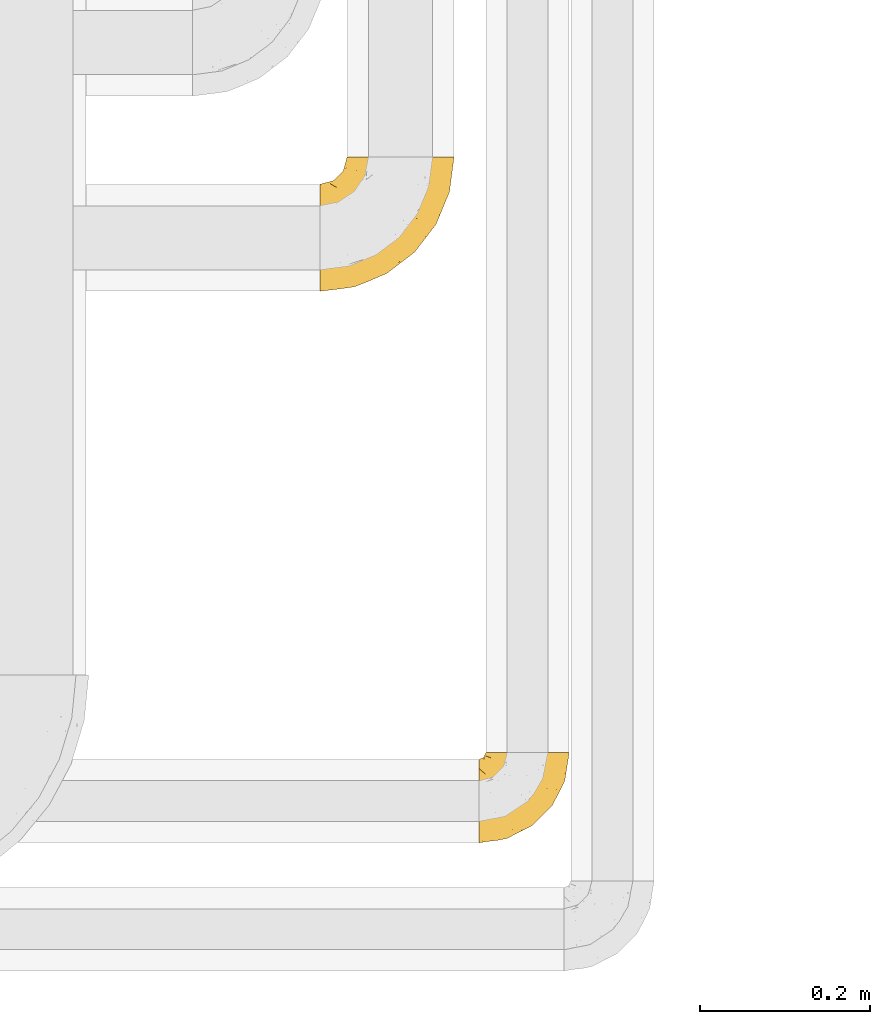
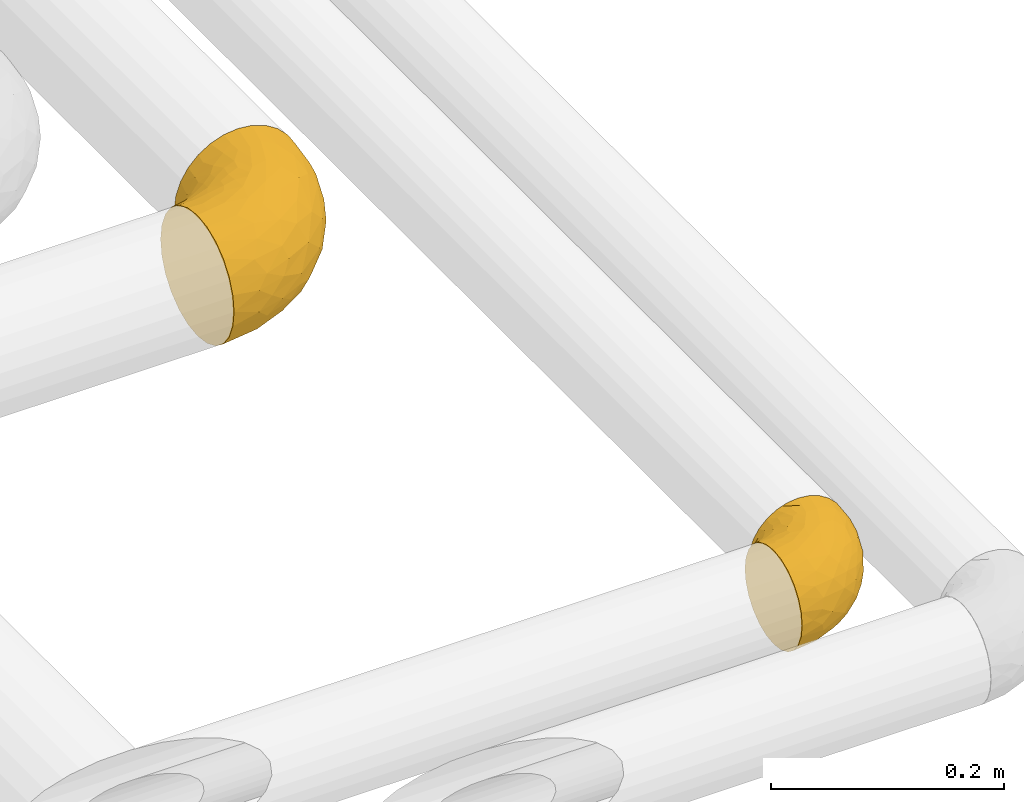
# One storey, part 486 of 827: 2 coverings.
"""IFC2X3 building model written with IfcOpenShell, lengths in millimetres."""

from ifc_helpers import new_model, entity, si_unit, converted_unit, derived_unit, direction, frame, origin, place, context, subcontext, project, spatial, faceted_brep, element, save


model = new_model("IFC2X3")

# Units and contexts
model_context = context("Model", 3, precision=0.01, world=origin(), true_north=direction((6.12303176911189e-17, 1.0)))
body_context = subcontext(model_context, "Body", "Model", "MODEL_VIEW")
ifc_project = project(units=[si_unit("LENGTHUNIT", "METRE", prefix="MILLI"), si_unit("AREAUNIT", "SQUARE_METRE"), si_unit("VOLUMEUNIT", "CUBIC_METRE"), converted_unit("PLANEANGLEUNIT", "DEGREE", entity("IfcRatioMeasure", 0.0174532925199433), si_unit("PLANEANGLEUNIT", "RADIAN"), dimensions=[0, 0, 0, 0, 0, 0, 0]), si_unit("MASSUNIT", "GRAM", prefix="KILO"), derived_unit("MASSDENSITYUNIT", [(si_unit("MASSUNIT", "GRAM", prefix="KILO"), 1), (si_unit("LENGTHUNIT", "METRE"), -3)]), derived_unit("MOMENTOFINERTIAUNIT", [(si_unit("LENGTHUNIT", "METRE"), 4)]), si_unit("TIMEUNIT", "SECOND"), si_unit("FREQUENCYUNIT", "HERTZ"), si_unit("THERMODYNAMICTEMPERATUREUNIT", "DEGREE_CELSIUS"), derived_unit("THERMALTRANSMITTANCEUNIT", [(si_unit("MASSUNIT", "GRAM", prefix="KILO"), 1), (si_unit("THERMODYNAMICTEMPERATUREUNIT", "KELVIN"), -1), (si_unit("TIMEUNIT", "SECOND"), -3)]), derived_unit("VOLUMETRICFLOWRATEUNIT", [(si_unit("LENGTHUNIT", "METRE"), 3), (si_unit("TIMEUNIT", "SECOND"), -1)]), derived_unit("MASSFLOWRATEUNIT", [(si_unit("MASSUNIT", "GRAM", prefix="KILO"), 1), (si_unit("TIMEUNIT", "SECOND"), -1)]), derived_unit("ROTATIONALFREQUENCYUNIT", [(si_unit("TIMEUNIT", "SECOND"), -1)]), si_unit("ELECTRICCURRENTUNIT", "AMPERE"), si_unit("ELECTRICVOLTAGEUNIT", "VOLT"), si_unit("POWERUNIT", "WATT"), si_unit("FORCEUNIT", "NEWTON", prefix="KILO"), si_unit("ILLUMINANCEUNIT", "LUX"), si_unit("LUMINOUSFLUXUNIT", "LUMEN"), si_unit("LUMINOUSINTENSITYUNIT", "CANDELA"), derived_unit("USERDEFINED", [(si_unit("MASSUNIT", "GRAM", prefix="KILO"), -1), (si_unit("LENGTHUNIT", "METRE"), -2), (si_unit("TIMEUNIT", "SECOND"), 3), (si_unit("LUMINOUSFLUXUNIT", "LUMEN"), 1)]), derived_unit("LINEARVELOCITYUNIT", [(si_unit("LENGTHUNIT", "METRE"), 1), (si_unit("TIMEUNIT", "SECOND"), -1)]), si_unit("PRESSUREUNIT", "PASCAL"), derived_unit("USERDEFINED", [(si_unit("LENGTHUNIT", "METRE"), -2), (si_unit("MASSUNIT", "GRAM", prefix="KILO"), 1), (si_unit("TIMEUNIT", "SECOND"), -2)]), derived_unit("LINEARFORCEUNIT", [(si_unit("MASSUNIT", "GRAM", prefix="KILO"), 1), (si_unit("LENGTHUNIT", "METRE"), 1), (si_unit("TIMEUNIT", "SECOND"), -2), (si_unit("LENGTHUNIT", "METRE"), -1)]), derived_unit("PLANARFORCEUNIT", [(si_unit("MASSUNIT", "GRAM", prefix="KILO"), 1), (si_unit("LENGTHUNIT", "METRE"), 1), (si_unit("TIMEUNIT", "SECOND"), -2), (si_unit("LENGTHUNIT", "METRE"), -2)])], contexts=[model_context])

# Site, building, storey
site_placement = place(None, origin())
site = spatial("IfcSite", under=ifc_project, at=site_placement, CompositionType="ELEMENT")
building_placement = place(site_placement, origin())
building = spatial("IfcBuilding", under=site, at=building_placement, CompositionType="ELEMENT")
storey_placement = place(building_placement, frame((0.0, 0.0, 28200.0)))
storey = spatial("IfcBuildingStorey", under=building, at=storey_placement, Name="08", CompositionType="ELEMENT", Elevation=28200.0)

# Coverings
covering_1_placement = place(storey_placement, frame((60806.51, 7015.35, 3035.35)))
element("IfcCovering", 1, at=covering_1_placement, inside=storey, Name=":ADSK_", ObjectType=":ADSK_", PredefinedType="INSULATION", context=body_context, shape_type="Brep", body=[
    faceted_brep([(110.62, 159.65, 126.11), (123.95, 159.65, 121.45), (135.9, 159.65, 113.94), (145.89, 159.65, 103.96), (153.4, 159.65, 92.0), (158.06, 159.65, 78.68), (159.65, 159.65, 64.65), (158.06, 159.65, 50.62), (153.4, 159.65, 37.29), (145.89, 159.65, 25.34), (135.91, 159.65, 15.35), (123.95, 159.65, 7.84), (110.63, 159.65, 3.18), (96.6, 159.65, 1.6), (82.57, 159.65, 3.18), (69.24, 159.65, 7.84), (57.29, 159.65, 15.35), (47.3, 159.65, 25.33), (39.79, 159.65, 37.29), (35.13, 159.65, 50.61), (33.55, 159.65, 64.65), (35.13, 159.65, 78.67), (39.79, 159.65, 92.0), (47.3, 159.65, 103.95), (57.28, 159.65, 113.94), (69.24, 159.65, 121.45), (82.56, 159.65, 126.11), (96.6, 159.65, 127.7), (1.6, 127.7, 64.65), (1.6, 125.55, 48.33), (1.6, 119.25, 33.12), (1.6, 109.23, 20.06), (1.6, 96.17, 10.04), (1.6, 80.96, 3.74), (1.6, 75.35, 3.01), (1.6, 64.65, 1.6), (1.6, 48.33, 3.74), (1.6, 33.12, 10.04), (1.6, 20.06, 20.06), (1.6, 10.04, 33.12), (1.6, 3.74, 48.33), (1.6, 1.6, 64.65), (1.6, 3.74, 80.96), (1.6, 10.04, 96.17), (1.6, 20.06, 109.23), (1.6, 33.12, 119.25), (1.6, 48.33, 125.55), (1.6, 64.65, 127.7), (1.6, 75.35, 126.29), (1.6, 80.96, 125.55), (1.6, 96.17, 119.25), (1.6, 109.23, 109.23), (1.6, 119.25, 96.17), (1.6, 125.55, 80.96), (30.13, 16.01, 101.1), (39.4, 10.29, 86.72), (62.65, 24.76, 98.7), (28.52, 4.94, 75.93), (42.5, 6.98, 64.65), (115.57, 87.32, 113.39), (98.94, 62.3, 111.06), (111.29, 58.52, 96.87), (95.5, 36.35, 84.07), (80.62, 22.77, 64.65), (113.35, 47.89, 64.65), (43.71, 40.91, 119.56), (70.76, 42.82, 112.75), (62.71, 57.25, 122.85), (33.16, 51.19, 125.08), (53.41, 66.64, 126.64), (130.65, 98.56, 105.78), (137.68, 94.44, 93.81), (146.84, 123.53, 96.07), (66.58, 20.12, 87.11), (57.7, 12.95, 75.77), (39.88, 28.48, 111.99), (154.26, 118.74, 64.65), (152.07, 121.88, 83.58), (125.54, 65.08, 80.96), (142.81, 92.08, 78.34), (103.99, 98.53, 122.85), (79.4, 81.84, 125.88), (88.81, 72.43, 120.97), (104.86, 134.31, 126.67), (117.38, 129.11, 122.64), (57.43, 82.79, 127.7), (44.19, 76.04, 127.7), (30.95, 69.29, 127.7), (139.96, 129.58, 107.12), (127.03, 115.86, 115.07), (87.17, 42.36, 102.81), (78.45, 103.81, 127.7), (73.2, 98.55, 127.7), (67.94, 93.3, 127.7), (94.63, 147.25, 127.7), (93.29, 138.77, 127.7), (91.95, 130.29, 127.7), (94.6, 107.83, 126.64), (85.2, 117.05, 127.7), (138.47, 80.62, 64.65), (13.99, 66.61, 127.7), (40.46, 121.29, 113.05), (32.36, 128.09, 101.81), (28.71, 118.04, 108.46), (15.53, 79.47, 126.21), (29.06, 94.94, 122.65), (40.03, 86.01, 126.55), (45.36, 94.69, 125.45), (26.46, 83.06, 126.01), (47.56, 104.39, 123.3), (36.28, 107.01, 118.99), (55.57, 148.3, 113.51), (45.02, 143.82, 104.6), (57.55, 134.19, 118.04), (11.56, 116.87, 101.6), (19.2, 111.58, 109.98), (10.07, 122.36, 92.1), (21.04, 124.16, 96.28), (15.52, 94.28, 121.05), (13.84, 128.25, 79.4), (32.67, 146.72, 79.19), (24.86, 134.92, 80.39), (34.31, 138.87, 93.14), (81.47, 133.28, 126.75), (71.26, 121.77, 125.71), (81.64, 145.83, 126.17), (29.26, 143.67, 64.65), (70.65, 139.93, 123.28), (31.93, 153.63, 64.65), (27.99, 132.32, 91.58), (41.71, 132.59, 107.1), (50.14, 126.42, 116.28), (17.57, 102.97, 116.32), (37.62, 149.52, 90.34), (60.48, 120.88, 122.74), (17.57, 131.98, 64.65), (56.96, 96.12, 126.77), (48.98, 115.84, 119.84), (57.29, 108.2, 124.71), (68.25, 110.85, 126.47), (10.07, 122.36, 37.19), (16.58, 118.35, 27.66), (13.84, 128.25, 49.9), (13.99, 66.61, 1.6), (32.67, 146.72, 50.1), (24.86, 134.92, 48.89), (67.81, 110.73, 2.88), (61.09, 121.83, 6.55), (71.26, 121.77, 3.58), (57.43, 82.79, 1.6), (44.19, 76.04, 1.6), (40.03, 86.01, 2.74), (57.55, 134.19, 11.25), (51.01, 124.9, 11.93), (42.79, 132.35, 21.09), (26.46, 83.06, 3.28), (29.06, 94.94, 6.64), (17.57, 102.97, 12.97), (19.2, 111.58, 19.31), (40.46, 121.29, 16.23), (28.84, 118.82, 21.44), (33.48, 128.68, 26.96), (15.52, 94.28, 8.24), (15.53, 79.47, 3.08), (36.28, 107.01, 10.3), (37.62, 149.51, 38.95), (21.04, 124.16, 33.01), (94.63, 147.25, 1.6), (93.29, 138.77, 1.6), (34.31, 138.87, 36.15), (45.03, 143.82, 24.69), (70.65, 139.92, 6.01), (81.47, 133.28, 2.54), (55.58, 148.3, 15.78), (91.95, 130.29, 1.6), (81.64, 145.83, 3.12), (27.86, 131.94, 37.33), (78.45, 103.81, 1.6), (85.2, 117.05, 1.6), (56.96, 96.12, 2.52), (45.36, 94.69, 3.84), (47.57, 104.39, 5.99), (48.27, 114.83, 9.35), (67.94, 93.3, 1.6), (57.3, 108.2, 4.58), (30.95, 69.29, 1.6), (62.65, 24.76, 30.59), (30.13, 16.01, 28.19), (39.88, 28.48, 17.3), (43.71, 40.91, 9.73), (39.4, 10.29, 42.57), (55.79, 12.23, 53.51), (28.41, 4.91, 53.42), (53.41, 66.64, 2.65), (104.86, 134.31, 2.62), (117.39, 129.11, 6.66), (103.99, 98.53, 6.44), (125.54, 65.08, 48.33), (111.29, 58.52, 32.42), (137.69, 94.45, 35.49), (94.6, 107.83, 2.65), (79.4, 81.84, 3.41), (33.16, 51.19, 4.21), (68.78, 20.8, 43.07), (130.66, 98.56, 23.52), (139.97, 129.58, 22.18), (148.6, 131.93, 33.1), (115.58, 87.32, 15.9), (127.03, 115.86, 14.23), (70.76, 42.82, 16.54), (95.5, 36.35, 45.22), (62.71, 57.25, 6.44), (88.81, 72.43, 8.33), (98.94, 62.3, 18.23), (89.09, 38.39, 32.99), (78.72, 22.86, 53.35), (142.21, 92.06, 48.76), (152.07, 121.88, 45.72)], [[[0, 1, 2, 3, 4, 5, 6, 7, 8, 9, 10, 11, 12, 13, 14, 15, 16, 17, 18, 19, 20, 21, 22, 23, 24, 25, 26, 27]], [[28, 29, 30, 31, 32, 33, 34, 35, 36, 37, 38, 39, 40, 41, 42, 43, 44, 45, 46, 47, 48, 49, 50, 51, 52, 53]], [[54, 55, 56]], [[57, 41, 58]], [[59, 60, 61]], [[62, 63, 64]], [[65, 66, 67]], [[68, 67, 69]], [[70, 71, 72]], [[55, 73, 56]], [[43, 42, 55]], [[55, 74, 73]], [[44, 75, 45]], [[44, 43, 54]], [[76, 5, 77]], [[71, 78, 79]], [[45, 75, 65]], [[46, 68, 47]], [[80, 81, 82]], [[0, 83, 84]], [[69, 85, 86, 87]], [[69, 81, 85]], [[84, 1, 0]], [[2, 88, 3]], [[4, 3, 72]], [[44, 54, 75]], [[5, 4, 77]], [[89, 2, 1]], [[72, 3, 88]], [[5, 76, 6]], [[70, 88, 89]], [[68, 65, 67]], [[88, 2, 89]], [[56, 90, 66]], [[64, 78, 62]], [[81, 91, 92, 93, 85]], [[83, 27, 94, 95, 96]], [[62, 61, 90]], [[97, 96, 98, 91]], [[80, 97, 81]], [[42, 57, 55]], [[62, 78, 61]], [[84, 89, 1]], [[78, 64, 99]], [[57, 74, 55]], [[76, 77, 79]], [[77, 72, 71]], [[82, 81, 67]], [[97, 83, 96]], [[80, 89, 84]], [[79, 78, 99]], [[71, 70, 61]], [[81, 97, 91]], [[83, 80, 84]], [[68, 87, 100, 47]], [[81, 69, 67]], [[68, 69, 87]], [[65, 46, 45]], [[65, 68, 46]], [[66, 65, 75]], [[56, 66, 75]], [[66, 60, 82]], [[71, 61, 78]], [[60, 66, 90]], [[83, 97, 80]], [[27, 83, 0]], [[59, 70, 89]], [[70, 59, 61]], [[89, 80, 59]], [[82, 59, 80]], [[55, 54, 43]], [[75, 54, 56]], [[66, 82, 67]], [[59, 82, 60]], [[41, 57, 42]], [[74, 57, 58]], [[58, 63, 74]], [[62, 74, 63]], [[74, 62, 73]], [[62, 56, 73]], [[4, 72, 77]], [[70, 72, 88]], [[76, 79, 99]], [[71, 79, 77]], [[62, 90, 56]], [[60, 90, 61]], [[101, 102, 103]], [[100, 87, 104]], [[105, 106, 107]], [[108, 104, 87]], [[107, 109, 110]], [[108, 87, 86]], [[111, 112, 113]], [[114, 51, 115]], [[116, 114, 117]], [[51, 50, 118]], [[119, 28, 53]], [[120, 121, 122]], [[98, 123, 124]], [[125, 96, 95]], [[116, 53, 52]], [[126, 121, 120]], [[104, 108, 118]], [[98, 124, 91]], [[25, 24, 127]], [[120, 128, 126]], [[122, 129, 102]], [[95, 94, 27, 26]], [[122, 102, 130]], [[125, 127, 123]], [[24, 111, 127]], [[21, 20, 128]], [[112, 130, 131]], [[48, 47, 100, 49]], [[132, 110, 115]], [[23, 111, 24]], [[129, 119, 117]], [[120, 133, 21]], [[112, 23, 22]], [[134, 113, 131]], [[121, 126, 135]], [[133, 112, 22]], [[128, 120, 21]], [[132, 51, 118]], [[120, 122, 133]], [[119, 121, 135]], [[129, 117, 102]], [[125, 26, 25]], [[26, 125, 95]], [[127, 125, 25]], [[28, 119, 135]], [[119, 53, 116]], [[127, 113, 124]], [[96, 125, 123]], [[112, 131, 113]], [[101, 103, 110]], [[85, 93, 136]], [[124, 123, 127]], [[98, 96, 123]], [[112, 111, 23]], [[127, 111, 113]], [[112, 133, 122]], [[21, 133, 22]], [[107, 110, 105]], [[110, 109, 137]], [[86, 106, 108]], [[138, 109, 136]], [[105, 118, 108]], [[107, 106, 85]], [[104, 50, 49]], [[124, 134, 139]], [[138, 93, 92]], [[92, 91, 139]], [[100, 104, 49]], [[118, 105, 132]], [[104, 118, 50]], [[110, 132, 105]], [[51, 132, 115]], [[108, 106, 105]], [[85, 106, 86]], [[114, 116, 52]], [[119, 116, 117]], [[51, 114, 52]], [[114, 115, 103]], [[117, 114, 103]], [[130, 102, 101]], [[117, 103, 102]], [[110, 103, 115]], [[130, 101, 131]], [[122, 130, 112]], [[101, 137, 131]], [[113, 134, 124]], [[137, 134, 131]], [[124, 139, 91]], [[134, 138, 139]], [[92, 139, 138]], [[110, 137, 101]], [[134, 137, 138]], [[136, 109, 107]], [[137, 109, 138]], [[85, 136, 107]], [[138, 136, 93]], [[122, 121, 129]], [[129, 121, 119]], [[30, 140, 141]], [[30, 29, 140]], [[28, 135, 142]], [[143, 35, 34, 33]], [[19, 144, 128]], [[126, 145, 135]], [[146, 147, 148]], [[149, 150, 151]], [[152, 153, 154]], [[155, 156, 151]], [[157, 31, 158]], [[159, 160, 161]], [[32, 162, 163]], [[158, 31, 30]], [[157, 164, 156]], [[126, 144, 145]], [[126, 128, 144]], [[18, 165, 19]], [[141, 166, 160]], [[14, 13, 167, 168]], [[163, 143, 33]], [[169, 165, 170]], [[18, 17, 170]], [[153, 159, 154]], [[142, 135, 145]], [[148, 171, 172]], [[159, 161, 154]], [[171, 152, 173]], [[173, 17, 16]], [[16, 15, 171]], [[158, 160, 164]], [[174, 175, 168]], [[173, 170, 17]], [[19, 128, 20]], [[174, 172, 175]], [[165, 169, 144]], [[162, 157, 156]], [[175, 172, 171]], [[144, 169, 145]], [[176, 169, 161]], [[166, 140, 142]], [[175, 171, 15]], [[168, 175, 14]], [[14, 175, 15]], [[142, 145, 176]], [[28, 142, 29]], [[148, 177, 146]], [[148, 178, 177]], [[152, 171, 148]], [[179, 180, 181]], [[164, 180, 156]], [[174, 178, 172]], [[148, 172, 178]], [[171, 173, 16]], [[170, 173, 152]], [[19, 165, 144]], [[170, 165, 18]], [[153, 182, 159]], [[146, 183, 184]], [[181, 180, 164]], [[180, 151, 156]], [[163, 155, 185]], [[155, 150, 185]], [[162, 156, 155]], [[143, 163, 185]], [[180, 179, 149]], [[32, 163, 33]], [[163, 162, 155]], [[31, 162, 32]], [[31, 157, 162]], [[164, 157, 158]], [[149, 151, 180]], [[155, 151, 150]], [[142, 140, 29]], [[141, 140, 166]], [[176, 145, 169]], [[30, 141, 158]], [[164, 160, 159]], [[158, 141, 160]], [[166, 161, 160]], [[154, 169, 170]], [[169, 154, 161]], [[152, 154, 170]], [[147, 152, 148]], [[153, 147, 182]], [[181, 182, 184]], [[164, 159, 182]], [[161, 166, 176]], [[142, 176, 166]], [[183, 146, 177]], [[184, 182, 147]], [[184, 147, 146]], [[152, 147, 153]], [[182, 181, 164]], [[179, 184, 183]], [[184, 179, 181]], [[149, 179, 183]], [[186, 187, 188]], [[37, 36, 189]], [[190, 191, 192]], [[193, 185, 150, 149]], [[194, 195, 196]], [[197, 198, 199]], [[200, 201, 177]], [[193, 202, 185]], [[203, 190, 186]], [[202, 189, 36]], [[41, 40, 192]], [[204, 205, 199]], [[9, 8, 206]], [[187, 190, 39]], [[40, 39, 190]], [[38, 37, 188]], [[207, 208, 204]], [[202, 35, 143, 185]], [[39, 38, 187]], [[195, 11, 208]], [[201, 149, 183, 177]], [[188, 189, 209]], [[197, 64, 210]], [[186, 188, 209]], [[13, 12, 194]], [[211, 201, 212]], [[12, 11, 195]], [[193, 201, 211]], [[212, 201, 196]], [[10, 208, 11]], [[213, 214, 209]], [[64, 63, 215]], [[216, 197, 199]], [[8, 217, 206]], [[7, 217, 8]], [[203, 191, 190]], [[7, 6, 76]], [[208, 205, 204]], [[205, 10, 9]], [[199, 205, 206]], [[7, 76, 217]], [[205, 208, 10]], [[216, 76, 99]], [[200, 177, 178, 174]], [[64, 197, 99]], [[63, 58, 191]], [[208, 196, 195]], [[196, 200, 194]], [[198, 197, 210]], [[216, 199, 217]], [[201, 193, 149]], [[202, 193, 211]], [[202, 211, 189]], [[35, 202, 36]], [[211, 212, 209]], [[37, 189, 188]], [[211, 209, 189]], [[213, 198, 214]], [[200, 174, 194]], [[201, 200, 196]], [[214, 198, 210]], [[213, 207, 198]], [[194, 174, 168, 167, 13]], [[195, 194, 12]], [[198, 204, 199]], [[204, 198, 207]], [[212, 207, 213]], [[196, 208, 207]], [[188, 187, 38]], [[190, 187, 186]], [[207, 212, 196]], [[209, 212, 213]], [[214, 203, 186]], [[191, 215, 63]], [[191, 203, 215]], [[192, 191, 58]], [[41, 192, 58]], [[190, 192, 40]], [[203, 210, 215]], [[64, 215, 210]], [[199, 206, 217]], [[9, 206, 205]], [[76, 216, 217]], [[99, 197, 216]], [[203, 214, 210]], [[209, 214, 186]]]),
])
covering_2_placement = place(storey_placement, frame((60994.04, 6365.82, 3049.25)))
element("IfcCovering", 2, at=covering_2_placement, inside=storey, Name=":ADSK_", ObjectType=":ADSK_", PredefinedType="INSULATION", context=body_context, shape_type="Brep", body=[
    faceted_brep([(58.6, 107.75, 99.9), (69.54, 107.75, 98.66), (79.93, 107.75, 95.02), (89.25, 107.75, 89.17), (97.03, 107.75, 81.38), (102.88, 107.75, 72.06), (106.51, 107.75, 61.68), (107.75, 107.75, 50.75), (106.51, 107.75, 39.8), (102.87, 107.75, 29.41), (97.02, 107.75, 20.09), (89.23, 107.75, 12.31), (79.91, 107.75, 6.46), (69.53, 107.75, 2.83), (58.6, 107.75, 1.6), (52.89, 107.75, 2.24), (47.65, 107.75, 2.83), (42.46, 107.75, 4.65), (37.26, 107.75, 6.47), (27.94, 107.75, 12.32), (20.16, 107.75, 20.11), (14.31, 107.75, 29.43), (10.68, 107.75, 39.81), (9.45, 107.75, 50.75), (10.68, 107.75, 61.69), (14.32, 107.75, 72.08), (20.17, 107.75, 81.4), (27.96, 107.75, 89.18), (37.28, 107.75, 95.03), (42.47, 107.75, 96.85), (47.66, 107.75, 98.66), (52.89, 107.75, 99.25), (55.75, 107.75, 99.57), (1.6, 98.22, 38.02), (1.6, 93.31, 26.17), (1.6, 89.4, 21.08), (1.6, 85.5, 15.99), (1.6, 80.41, 12.09), (1.6, 75.32, 8.18), (1.6, 69.39, 5.73), (1.6, 63.47, 3.27), (1.6, 56.48, 2.35), (1.6, 53.61, 1.97), (1.6, 50.75, 1.6), (1.6, 38.02, 3.27), (1.6, 26.17, 8.18), (1.6, 15.99, 15.99), (1.6, 8.18, 26.17), (1.6, 3.27, 38.02), (1.6, 1.6, 50.75), (1.6, 3.27, 63.47), (1.6, 8.18, 75.32), (1.6, 15.99, 85.5), (1.6, 26.17, 93.31), (1.6, 38.02, 98.22), (1.6, 50.75, 99.9), (1.6, 56.48, 99.14), (1.6, 63.47, 98.22), (1.6, 69.39, 95.77), (1.6, 75.32, 93.31), (1.6, 80.41, 89.4), (1.6, 85.5, 85.5), (1.6, 89.4, 80.41), (1.6, 93.31, 75.32), (1.6, 98.22, 63.47), (1.6, 99.9, 50.75), (69.96, 27.53, 59.31), (59.59, 25.32, 73.08), (51.96, 16.29, 63.72), (34.4, 6.79, 50.75), (23.37, 4.51, 58.64), (13.68, 3.51, 50.75), (41.52, 17.47, 76.74), (26.26, 7.6, 67.68), (20.18, 12.27, 78.92), (72.33, 70.89, 94.31), (65.88, 87.17, 98.76), (57.55, 67.3, 98.4), (23.76, 31.65, 94.57), (46.5, 33.58, 89.91), (46.57, 47.23, 96.32), (21.17, 43.26, 98.79), (23.41, 55.08, 99.9), (17.92, 53.99, 99.9), (12.43, 52.9, 99.9), (9.72, 52.36, 99.9), (7.01, 51.82, 99.9), (26.77, 21.5, 87.31), (76.59, 89.94, 95.61), (95.55, 60.45, 60.43), (102.57, 83.0, 65.24), (92.89, 64.79, 72.87), (54.26, 85.93, 99.9), (51.17, 81.31, 99.9), (48.08, 76.69, 99.9), (44.99, 72.06, 99.9), (41.9, 67.44, 99.9), (85.16, 88.74, 90.65), (85.97, 45.98, 63.14), (59.58, 47.13, 91.89), (99.5, 89.4, 75.25), (105.83, 95.66, 50.75), (53.59, 28.5, 82.18), (67.0, 42.81, 85.08), (71.56, 38.28, 76.93), (87.47, 45.35, 50.75), (75.73, 33.61, 50.75), (92.24, 82.57, 83.02), (58.06, 105.04, 99.9), (57.52, 102.33, 99.9), (56.44, 96.91, 99.9), (55.35, 91.42, 99.9), (81.33, 65.92, 87.13), (80.35, 53.11, 80.85), (39.44, 54.37, 99.17), (102.55, 74.94, 50.75), (37.28, 64.35, 99.9), (32.65, 61.26, 99.9), (28.03, 58.17, 99.9), (63.99, 21.87, 50.75), (74.55, 34.79, 67.61), (83.62, 48.48, 72.25), (95.01, 60.15, 50.75), (49.19, 14.33, 50.75), (46.96, 99.07, 98.69), (8.77, 60.55, 99.01), (18.28, 64.18, 98.79), (11.68, 64.36, 98.29), (11.79, 103.17, 68.51), (15.69, 101.69, 76.82), (42.49, 87.75, 98.54), (47.41, 89.38, 99.3), (7.94, 88.34, 83.57), (9.27, 82.14, 89.47), (7.98, 94.51, 75.76), (13.4, 89.64, 84.86), (13.04, 98.41, 75.89), (7.36, 99.71, 64.77), (23.46, 89.37, 90.83), (30.46, 88.21, 94.62), (26.54, 95.2, 90.37), (6.76, 79.14, 91.18), (26.46, 101.22, 88.65), (20.77, 99.41, 84.11), (20.68, 84.72, 91.75), (40.26, 97.47, 96.86), (7.15, 102.19, 50.75), (9.28, 104.02, 58.97), (38.78, 82.66, 98.37), (18.27, 95.42, 83.91), (31.78, 78.67, 97.52), (12.75, 72.69, 95.55), (22.96, 66.46, 98.76), (17.55, 75.3, 95.26), (27.63, 72.74, 98.04), (15.23, 82.93, 90.65), (33.25, 99.27, 93.51), (32.43, 93.51, 94.16), (27.9, 67.35, 99.1), (7.97, 94.51, 25.73), (15.22, 82.94, 10.84), (7.93, 88.33, 17.92), (13.38, 89.64, 16.64), (13.12, 103.62, 30.44), (42.49, 87.74, 2.95), (47.4, 89.38, 2.19), (51.17, 81.31, 1.6), (40.24, 97.47, 4.63), (20.76, 99.41, 17.39), (12.43, 52.9, 1.6), (7.01, 51.82, 1.6), (4.31, 51.28, 1.6), (26.44, 101.21, 12.86), (26.52, 95.19, 11.13), (11.68, 64.36, 3.2), (12.75, 72.69, 5.94), (9.27, 82.13, 12.02), (17.55, 75.3, 6.23), (6.76, 79.14, 10.31), (33.21, 99.28, 8.0), (32.41, 93.51, 7.34), (8.77, 60.55, 2.48), (22.96, 66.46, 2.73), (18.48, 63.96, 2.64), (56.44, 96.91, 1.6), (46.95, 99.06, 2.8), (7.36, 99.7, 36.71), (17.92, 53.99, 1.6), (23.41, 55.08, 1.6), (9.85, 103.3, 38.59), (57.52, 102.33, 1.6), (56.98, 99.62, 1.6), (48.08, 76.69, 1.6), (38.78, 82.66, 3.12), (18.25, 95.42, 17.59), (44.99, 72.06, 1.6), (31.74, 78.68, 3.98), (30.45, 88.2, 6.87), (27.63, 72.75, 3.45), (20.65, 84.74, 9.76), (55.35, 91.42, 1.6), (54.26, 85.93, 1.6), (13.03, 98.41, 25.62), (23.44, 89.37, 10.67), (27.9, 67.35, 2.39), (32.65, 61.26, 1.6), (28.03, 58.17, 1.6), (37.28, 64.35, 1.6), (41.9, 67.44, 1.6), (39.74, 54.08, 2.4), (23.37, 4.51, 42.85), (26.77, 21.5, 14.18), (46.18, 33.43, 11.56), (53.54, 28.5, 19.27), (41.53, 17.47, 24.75), (59.61, 25.36, 28.37), (76.79, 90.18, 5.95), (66.11, 86.97, 2.79), (21.17, 43.26, 2.71), (51.96, 16.29, 37.78), (26.26, 7.6, 33.81), (20.18, 12.27, 22.57), (23.76, 31.65, 6.92), (92.88, 64.79, 28.61), (102.57, 83.0, 36.24), (95.54, 60.44, 41.05), (71.63, 38.35, 24.55), (74.55, 34.8, 33.88), (72.51, 71.54, 7.11), (69.96, 27.53, 42.18), (92.23, 82.57, 18.46), (85.15, 88.74, 10.84), (80.45, 53.19, 20.69), (83.65, 48.49, 29.27), (57.57, 67.28, 3.1), (63.68, 52.32, 9.18), (85.95, 45.94, 38.38), (99.49, 89.4, 26.23), (81.23, 65.75, 14.34), (47.07, 46.73, 5.46), (66.99, 42.82, 16.39)], [[[0, 1, 2, 3, 4, 5, 6, 7, 8, 9, 10, 11, 12, 13, 14, 15, 16, 17, 18, 19, 20, 21, 22, 23, 24, 25, 26, 27, 28, 29, 30, 31, 32]], [[33, 34, 35, 36, 37, 38, 39, 40, 41, 42, 43, 44, 45, 46, 47, 48, 49, 50, 51, 52, 53, 54, 55, 56, 57, 58, 59, 60, 61, 62, 63, 64, 65]], [[66, 67, 68]], [[69, 70, 71]], [[68, 72, 73]], [[73, 72, 74]], [[75, 76, 77]], [[78, 79, 80]], [[51, 50, 73]], [[81, 82, 83, 84, 85, 86, 55]], [[52, 87, 53]], [[74, 52, 51]], [[2, 1, 88]], [[89, 90, 91]], [[77, 92, 93, 94, 95, 96]], [[55, 54, 81]], [[78, 53, 87]], [[5, 90, 6]], [[88, 76, 75]], [[97, 3, 2]], [[89, 91, 98]], [[99, 80, 79]], [[90, 5, 100]], [[74, 87, 52]], [[100, 5, 4]], [[90, 101, 6]], [[79, 102, 103]], [[102, 67, 104]], [[105, 98, 106]], [[107, 4, 3]], [[76, 0, 108, 109, 110, 111, 92]], [[107, 112, 113]], [[114, 77, 96]], [[89, 115, 90]], [[114, 96, 116, 117, 118, 82]], [[75, 97, 88]], [[119, 66, 68]], [[50, 71, 70]], [[100, 91, 90]], [[99, 77, 80]], [[102, 104, 103]], [[97, 107, 3]], [[80, 81, 78]], [[107, 97, 112]], [[68, 73, 70]], [[66, 98, 120]], [[78, 81, 54]], [[114, 81, 80]], [[53, 78, 54]], [[78, 87, 79]], [[102, 87, 72]], [[79, 103, 99]], [[4, 107, 100]], [[91, 100, 107]], [[88, 97, 2]], [[112, 97, 75]], [[99, 112, 75]], [[103, 104, 113]], [[91, 121, 98]], [[89, 105, 122, 115]], [[101, 90, 115]], [[101, 7, 6]], [[88, 1, 76]], [[0, 76, 1]], [[92, 77, 76]], [[73, 74, 51]], [[87, 74, 72]], [[81, 114, 82]], [[77, 114, 80]], [[87, 102, 79]], [[67, 102, 72]], [[68, 67, 72]], [[67, 120, 104]], [[120, 121, 104]], [[104, 121, 113]], [[121, 120, 98]], [[91, 107, 113]], [[91, 113, 121]], [[103, 113, 112]], [[106, 98, 66]], [[105, 89, 98]], [[106, 66, 119]], [[67, 66, 120]], [[68, 69, 123, 119]], [[50, 49, 71]], [[50, 70, 73]], [[112, 99, 103]], [[77, 99, 75]], [[69, 68, 70]], [[29, 124, 110]], [[84, 83, 125]], [[126, 82, 118]], [[59, 58, 127]], [[25, 128, 129]], [[130, 93, 131]], [[132, 62, 133]], [[134, 135, 136]], [[137, 65, 64]], [[64, 134, 137]], [[138, 139, 140]], [[111, 110, 124, 92]], [[134, 136, 137]], [[134, 64, 63]], [[141, 61, 60]], [[125, 58, 57]], [[142, 143, 140]], [[142, 26, 143]], [[127, 83, 82]], [[28, 124, 29]], [[108, 0, 32, 31, 30, 110, 109]], [[30, 29, 110]], [[135, 144, 138]], [[28, 145, 124]], [[57, 56, 55, 86, 85, 84]], [[146, 147, 23]], [[24, 23, 147]], [[25, 143, 26]], [[95, 94, 148]], [[24, 128, 25]], [[149, 138, 143]], [[124, 145, 131]], [[127, 58, 125]], [[150, 148, 139]], [[127, 126, 151]], [[151, 59, 127]], [[152, 151, 126]], [[153, 154, 155]], [[153, 133, 141]], [[145, 28, 27]], [[142, 156, 27]], [[157, 148, 130]], [[61, 133, 62]], [[134, 132, 135]], [[147, 128, 24]], [[65, 137, 146]], [[146, 137, 147]], [[128, 137, 136]], [[137, 128, 147]], [[128, 136, 129]], [[149, 129, 136]], [[25, 129, 143]], [[158, 152, 117]], [[152, 118, 117]], [[153, 151, 152]], [[158, 116, 154]], [[144, 150, 138]], [[153, 152, 158]], [[133, 153, 155]], [[133, 155, 132]], [[60, 151, 141]], [[135, 132, 155]], [[134, 63, 132]], [[144, 135, 155]], [[135, 138, 149]], [[155, 154, 144]], [[150, 154, 96]], [[154, 150, 144]], [[148, 94, 130]], [[82, 126, 127]], [[118, 152, 126]], [[150, 96, 95]], [[139, 148, 157]], [[150, 95, 148]], [[93, 92, 131]], [[130, 145, 156]], [[130, 94, 93]], [[84, 125, 57]], [[127, 125, 83]], [[140, 139, 157]], [[150, 139, 138]], [[140, 157, 142]], [[138, 140, 143]], [[156, 142, 157]], [[27, 26, 142]], [[130, 156, 157]], [[145, 27, 156]], [[132, 63, 62]], [[124, 131, 92]], [[130, 131, 145]], [[129, 149, 143]], [[135, 149, 136]], [[141, 133, 61]], [[60, 59, 151]], [[141, 151, 153]], [[116, 96, 154]], [[153, 158, 154]], [[158, 117, 116]], [[34, 33, 159]], [[160, 161, 162]], [[22, 21, 163]], [[164, 165, 166]], [[19, 18, 167]], [[168, 21, 20]], [[42, 41, 40, 169, 170, 171, 43]], [[172, 173, 168]], [[174, 38, 175]], [[176, 177, 178]], [[179, 164, 180]], [[40, 181, 169]], [[182, 183, 175]], [[17, 184, 185]], [[65, 146, 186]], [[187, 174, 188]], [[23, 22, 189]], [[174, 39, 38]], [[15, 14, 190, 191, 184, 16]], [[181, 40, 39]], [[192, 193, 164]], [[194, 163, 168]], [[33, 186, 159]], [[180, 173, 172]], [[195, 196, 193]], [[18, 185, 167]], [[173, 180, 197]], [[198, 199, 196]], [[200, 201, 185, 184]], [[184, 17, 16]], [[18, 17, 185]], [[202, 159, 186]], [[194, 168, 203]], [[189, 163, 202]], [[204, 205, 182]], [[187, 181, 174]], [[160, 177, 176]], [[206, 183, 182]], [[206, 182, 205]], [[201, 165, 185]], [[165, 164, 167]], [[172, 179, 180]], [[202, 194, 162]], [[176, 161, 160]], [[65, 186, 33]], [[163, 189, 22]], [[175, 177, 182]], [[174, 183, 188]], [[177, 198, 204]], [[199, 160, 162]], [[198, 207, 204]], [[175, 38, 37]], [[198, 177, 160]], [[178, 177, 175]], [[176, 35, 161]], [[34, 159, 161]], [[162, 161, 159]], [[202, 162, 159]], [[199, 162, 203]], [[196, 199, 203]], [[198, 160, 199]], [[193, 197, 180]], [[208, 198, 196]], [[188, 183, 206]], [[175, 183, 174]], [[193, 192, 195]], [[195, 208, 196]], [[197, 196, 203]], [[180, 164, 193]], [[168, 163, 21]], [[166, 165, 201]], [[166, 192, 164]], [[189, 202, 186]], [[186, 146, 189]], [[23, 189, 146]], [[174, 181, 39]], [[169, 181, 187]], [[196, 197, 193]], [[173, 203, 168]], [[203, 173, 197]], [[172, 168, 20]], [[20, 19, 172]], [[179, 172, 19]], [[19, 167, 179]], [[164, 179, 167]], [[35, 176, 36]], [[35, 34, 161]], [[185, 165, 167]], [[162, 194, 203]], [[163, 194, 202]], [[176, 178, 36]], [[37, 36, 178]], [[175, 37, 178]], [[177, 204, 182]], [[207, 198, 208]], [[207, 205, 204]], [[209, 188, 206, 205, 207, 208]], [[48, 210, 71]], [[211, 212, 213]], [[214, 213, 215]], [[216, 217, 13]], [[218, 43, 171, 170, 169, 187, 188]], [[219, 220, 214]], [[47, 46, 221]], [[210, 48, 220]], [[211, 222, 212]], [[222, 45, 44]], [[221, 220, 47]], [[47, 220, 48]], [[221, 211, 214]], [[223, 224, 225]], [[211, 46, 45]], [[226, 227, 215]], [[43, 218, 44]], [[217, 216, 228]], [[219, 215, 229]], [[14, 13, 217]], [[224, 9, 8]], [[10, 230, 11]], [[11, 231, 12]], [[232, 223, 233]], [[234, 208, 195, 192, 166, 201]], [[235, 234, 228]], [[222, 44, 218]], [[106, 229, 236]], [[224, 237, 9]], [[231, 238, 228]], [[9, 237, 10]], [[115, 224, 101]], [[239, 234, 235]], [[231, 11, 230]], [[223, 230, 237]], [[224, 8, 101]], [[223, 236, 233]], [[225, 115, 122, 105]], [[216, 12, 231]], [[209, 234, 239]], [[210, 219, 69]], [[219, 214, 215]], [[229, 119, 219]], [[209, 218, 188]], [[239, 212, 222]], [[239, 222, 218]], [[45, 222, 211]], [[235, 212, 239]], [[213, 212, 240]], [[223, 237, 224]], [[230, 10, 237]], [[238, 231, 230]], [[216, 231, 228]], [[232, 230, 223]], [[235, 238, 240]], [[115, 225, 224]], [[233, 236, 227]], [[8, 7, 101]], [[234, 209, 208]], [[218, 209, 239]], [[217, 228, 234]], [[13, 12, 216]], [[234, 201, 217]], [[217, 201, 200, 184, 191, 190, 14]], [[211, 221, 46]], [[220, 221, 214]], [[71, 210, 69]], [[71, 49, 48]], [[219, 210, 220]], [[226, 215, 213]], [[211, 213, 214]], [[226, 213, 240]], [[215, 227, 229]], [[232, 240, 238]], [[233, 227, 226]], [[232, 233, 226]], [[236, 223, 225]], [[240, 232, 226]], [[232, 238, 230]], [[225, 105, 236]], [[236, 105, 106]], [[236, 229, 227]], [[123, 69, 219, 119]], [[106, 119, 229]], [[238, 235, 228]], [[212, 235, 240]]]),
])

save(model, "model.ifc")
